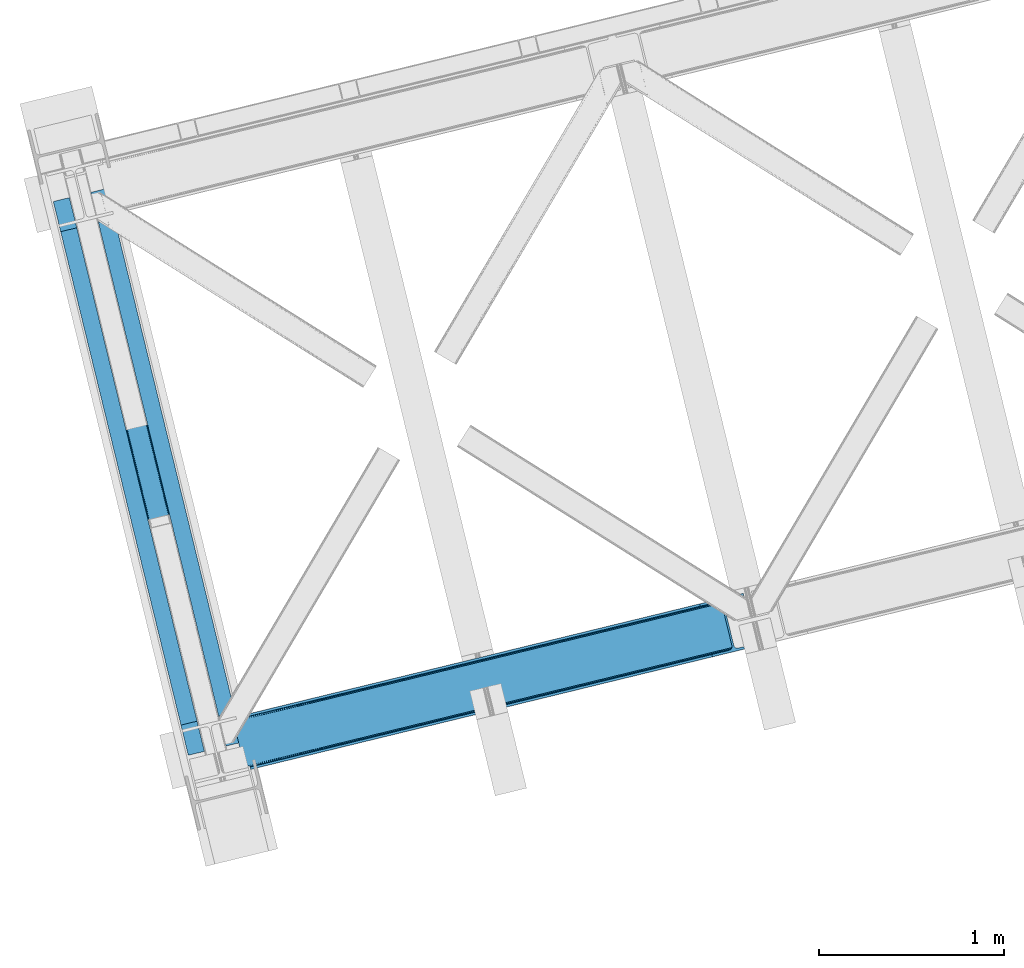
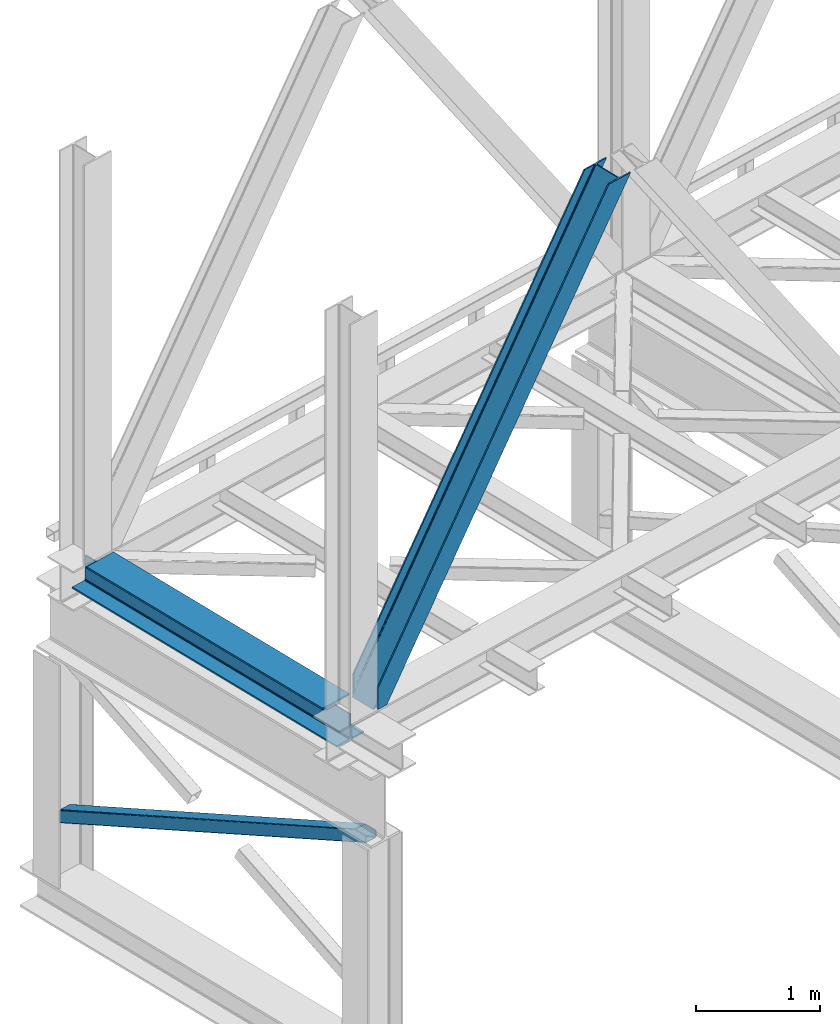
# One storey, part 23 of 93: 2 members, 1 beam.
"""IFC4 building model written with IfcOpenShell, lengths in millimetres."""

from ifc_helpers import new_model, entity, si_unit, converted_unit, derived_unit, direction, frame, origin, place, context, subcontext, project, spatial, triangles, polygons, material, type_object, element, save


model = new_model("IFC4")

# Units and contexts
model_context = context("Model", 3, precision=0.01, world=origin(), true_north=direction((6.12303176911189e-17, 1.0)))
plan_context = context("Plan", 3, precision=0.01, world=origin(), true_north=direction((6.12303176911189e-17, 1.0)))
body_context = subcontext(model_context, "Body", "Model", "MODEL_VIEW")
ifc_project = project(units=[si_unit("LENGTHUNIT", "METRE", prefix="MILLI"), si_unit("AREAUNIT", "SQUARE_METRE"), si_unit("VOLUMEUNIT", "CUBIC_METRE"), converted_unit("PLANEANGLEUNIT", "DEGREE", entity("IfcRatioMeasure", 0.0174532925199433), si_unit("PLANEANGLEUNIT", "RADIAN"), dimensions=[0, 0, 0, 0, 0, 0, 0]), si_unit("MASSUNIT", "GRAM", prefix="KILO"), derived_unit("MASSDENSITYUNIT", [(si_unit("MASSUNIT", "GRAM", prefix="KILO"), 1), (si_unit("LENGTHUNIT", "METRE"), -3)]), derived_unit("MOMENTOFINERTIAUNIT", [(si_unit("LENGTHUNIT", "METRE"), 4)]), si_unit("TIMEUNIT", "SECOND"), si_unit("FREQUENCYUNIT", "HERTZ"), si_unit("THERMODYNAMICTEMPERATUREUNIT", "DEGREE_CELSIUS"), derived_unit("THERMALTRANSMITTANCEUNIT", [(si_unit("MASSUNIT", "GRAM", prefix="KILO"), 1), (si_unit("THERMODYNAMICTEMPERATUREUNIT", "KELVIN"), -1), (si_unit("TIMEUNIT", "SECOND"), -3)]), derived_unit("VOLUMETRICFLOWRATEUNIT", [(si_unit("LENGTHUNIT", "METRE"), 3), (si_unit("TIMEUNIT", "SECOND"), -1)]), derived_unit("MASSFLOWRATEUNIT", [(si_unit("MASSUNIT", "GRAM", prefix="KILO"), 1), (si_unit("TIMEUNIT", "SECOND"), -1)]), derived_unit("ROTATIONALFREQUENCYUNIT", [(si_unit("TIMEUNIT", "SECOND"), -1)]), si_unit("ELECTRICCURRENTUNIT", "AMPERE"), si_unit("ELECTRICVOLTAGEUNIT", "VOLT"), si_unit("POWERUNIT", "WATT"), si_unit("FORCEUNIT", "NEWTON", prefix="KILO"), si_unit("ILLUMINANCEUNIT", "LUX"), si_unit("LUMINOUSFLUXUNIT", "LUMEN"), si_unit("LUMINOUSINTENSITYUNIT", "CANDELA"), derived_unit("USERDEFINED", [(si_unit("MASSUNIT", "GRAM", prefix="KILO"), -1), (si_unit("LENGTHUNIT", "METRE"), -2), (si_unit("TIMEUNIT", "SECOND"), 3), (si_unit("LUMINOUSFLUXUNIT", "LUMEN"), 1)]), derived_unit("LINEARVELOCITYUNIT", [(si_unit("LENGTHUNIT", "METRE"), 1), (si_unit("TIMEUNIT", "SECOND"), -1)]), si_unit("PRESSUREUNIT", "PASCAL"), derived_unit("USERDEFINED", [(si_unit("LENGTHUNIT", "METRE"), -2), (si_unit("MASSUNIT", "GRAM", prefix="KILO"), 1), (si_unit("TIMEUNIT", "SECOND"), -2)]), derived_unit("LINEARFORCEUNIT", [(si_unit("MASSUNIT", "GRAM", prefix="KILO"), 1), (si_unit("LENGTHUNIT", "METRE"), 1), (si_unit("TIMEUNIT", "SECOND"), -2), (si_unit("LENGTHUNIT", "METRE"), -1)]), derived_unit("PLANARFORCEUNIT", [(si_unit("MASSUNIT", "GRAM", prefix="KILO"), 1), (si_unit("LENGTHUNIT", "METRE"), 1), (si_unit("TIMEUNIT", "SECOND"), -2), (si_unit("LENGTHUNIT", "METRE"), -2)])], contexts=[model_context, plan_context])

# Site, building, storey
site_placement = place(None, origin())
site = spatial("IfcSite", under=ifc_project, at=site_placement, CompositionType="ELEMENT")
building_placement = place(site_placement, origin())
building = spatial("IfcBuilding", under=site, at=building_placement, CompositionType="ELEMENT")
storey_placement = place(building_placement, frame((0.0, 0.0, 15900.0)))
storey = spatial("IfcBuildingStorey", under=building, at=storey_placement, CompositionType="ELEMENT", Elevation=15900.0)

# Beam
ifc_material = material(Name="Metal painted (White)")
beam_type = type_object("IfcBeamType", PredefinedType="BEAM")
beam_placement = place(storey_placement, frame((-61153.9389306417, 2879.78519364395, 3385.0)))
element("IfcBeam", 1, at=beam_placement, inside=storey, type_object=beam_type, material=ifc_material, ObjectType="Steel Beam", PredefinedType="BEAM", context=body_context, shape_type="Tessellation", body=[
    polygons([(1022.42935345713, 71.0478278971005, 15.4999999999986), (1022.42935345711, 71.0478278971005, 0.0), (291.465617442429, 3069.74325535076, 0.0), (291.465617442446, 3069.74325535076, 15.4999999999986), (899.042242073153, 40.970914087328, 15.4999999999986), (168.078506058474, 3039.66634154099, 15.4999999999986), (892.34989829919, 39.3395844888232, 16.8701684147963), (161.386162284511, 3038.03501194248, 16.8701684147963), (886.676403198575, 37.9566100336508, 20.7720779386413), (155.712667183895, 3036.65203748731, 20.7720779386413), (882.88549497, 37.0325360459173, 26.6116982174294), (151.92175895532, 3035.72796349958, 26.6116982174294), (881.554305026603, 36.7080444135018, 33.500000000001), (150.590569011932, 3035.40347186716, 33.500000000001), (140.875048430514, 3033.03521093726, 33.500000000001), (140.875048430514, 3033.03521093726, 259.000000000002), (150.590569011924, 3035.40347186716, 259.000000000002), (-8.66293703438714e-12, 2998.69542745366, 0.0), (-8.66293703438714e-12, 2998.69542745366, 15.4999999999986), (123.387111383964, 3028.77234126343, 15.4999999999986), (130.079455157918, 3030.40367086194, 16.8701684147963), (135.752950258542, 3031.78664531711, 20.7720779386413), (139.543858487117, 3032.71071930484, 26.6116982174294), (881.554305026594, 36.7080444135013, 259.000000000002), (871.838784445184, 34.3397834835981, 259.000000000002), (871.838784445184, 34.3397834835981, 33.500000000001), (870.507594501779, 34.0152918511832, 26.6116982174294), (866.716686273221, 33.0912178634486, 20.7720779386413), (861.043191172597, 31.7082434082767, 16.8701684147963), (854.350847398634, 30.0769138097725, 15.4999999999986), (730.963736014671, -5.41433564649196e-13, 15.4999999999986), (730.963736014671, -5.41433564649196e-13, 0.0), (841.854534586231, 199.571930111228, 259.069791776412), (190.199733064555, 2872.911390143, 259.000000000002), (190.423126166404, 2871.99494573803, 259.61730333112), (190.43551501003, 2871.94412150426, 266.500003008253), (841.709355772731, 200.167408132522, 266.500002998871), (841.709705893475, 200.165971827788, 260.000004007589), (832.229597305436, 196.831858094284, 259.006343172366), (832.006227290712, 197.74830961273, 259.61730333112), (831.993838447078, 197.799133846503, 266.500003008253), (180.719997684385, 2869.57584721824, 266.500002998871), (180.719647563625, 2869.57728352297, 260.000004007589), (180.574841905289, 2870.17133233676, 259.07612046749), (180.484212483136, 2870.5431292131, 259.000000000002), (843.040843642659, 200.490677577208, 273.388305639783), (846.831120231346, 201.417342749121, 279.227924098781), (852.504191178885, 202.802057212798, 283.129832400619), (859.196382860018, 204.434010743611, 284.500000377228), (982.583411547862, 234.511263798722, 284.500000138971), (982.58174174121, 234.518113867454, 299.999995328161), (691.11631964394, 163.469484603412, 299.999995890962), (691.1179894506, 163.46263453468, 284.500000701776), (814.505018138427, 193.539887589791, 284.500000463519), (821.197505034574, 195.17063005637, 283.129832461069), (826.871416683335, 196.551895700895, 279.227924137322), (830.662951470335, 197.473399350192, 273.388305663684), (179.38850981445, 2869.25257777355, 273.388305639783), (175.598233225754, 2868.32591260164, 279.227924098781), (169.925162278215, 2866.94119813796, 283.129832400619), (163.232970597099, 2865.30924460715, 284.500000377228), (39.8459419092461, 2835.23199155204, 284.500000138971), (39.8476117159065, 2835.2251414833, 299.999995328161), (331.313033813168, 2906.27377074735, 299.999995890962), (331.311364006516, 2906.28062081608, 284.500000701776), (207.924335318672, 2876.20336776097, 284.500000463519), (201.231848422525, 2874.57262529439, 283.129832461069), (195.557936773773, 2873.19135964986, 279.227924137322), (191.766401986782, 2872.26985600057, 273.388305663684)], [[[1, 2, 3, 4]], [[5, 1, 4, 6]], [[7, 5, 6, 8]], [[9, 7, 8, 10]], [[11, 9, 10, 12]], [[13, 11, 12, 14]], [[15, 16, 17, 14, 12, 10, 8, 6, 4, 3, 18, 19, 20, 21, 22, 23]], [[13, 24, 25, 26, 27, 28, 29, 30, 31, 32, 2, 1, 5, 7, 9, 11]], [[2, 32, 18, 3]], [[32, 31, 19, 18]], [[31, 30, 20, 19]], [[27, 26, 15, 23]], [[28, 27, 23, 22]], [[29, 28, 22, 21]], [[30, 29, 21, 20]], [[33, 24, 13, 14, 17, 34, 35, 36, 37, 38]], [[25, 39, 40, 41, 42, 43, 44, 16, 15, 26]], [[39, 25, 24, 33]], [[45, 34, 17, 16]], [[41, 40, 38, 37, 46, 47, 48, 49, 50, 51, 52, 53, 54, 55, 56, 57]], [[42, 58, 59, 60, 61, 62, 63, 64, 65, 66, 67, 68, 69, 36, 35, 43]], [[46, 37, 36, 69]], [[47, 46, 69, 68]], [[48, 47, 68, 67]], [[49, 48, 67, 66]], [[50, 49, 66, 65]], [[51, 50, 65, 64]], [[52, 51, 64, 63]], [[53, 52, 63, 62]], [[54, 53, 62, 61]], [[55, 54, 61, 60]], [[56, 55, 60, 59]], [[57, 56, 59, 58]], [[41, 57, 58, 42]]], closed=False),
])

# Members
member_type_1 = type_object("IfcMemberType", PredefinedType="BRACE")
member_1_placement = place(storey_placement, frame((-60179.5639160156, 2803.33935241699, 3684.99990234375)))
element("IfcMember", 2, at=member_1_placement, inside=storey, type_object=member_type_1, ObjectType="Steel Vertical Brace", PredefinedType="BRACE", context=body_context, shape_type="Tessellation", body=[
    triangles([(58.5731689453096, 23.1982933044433, 0.0), (60.4660766601592, 15.4260932922361, 0.0), (59.1080200195283, 16.2394157409667, 0.781347656247817), (58.9684936523408, 15.0609992980958, 1.0697021484375), (78.1673217773423, 19.740655517578, 8.06229858398365), (78.1673217773423, 19.740655517578, 29.5563354492188), (72.7350952148408, 18.4163177490232, 0.0), (500.42061767578, 117.802693176269, 660.427130126951), (82.4554321289033, 19.9240745544435, 36.4024291992173), (86.4877441406279, 18.4526527404782, 44.3670593261704), (502.150744628903, 124.235730743408, 658.201684570311), (88.0643920898438, 17.2873168945312, 48.5435485839844), (2700.97932128907, 660.223363494873, 3921.00020141601), (2700.97001953125, 667.310721588135, 3921.00020141601), (2273.78214111328, 563.179286956787, 3287.10633544922), (2274.3169921875, 556.220118713379, 3287.88535766601), (2697.74696044922, 653.425231933594, 3921.00020141601), (2272.58686523438, 549.787371826172, 3290.11080322265), (2691.77058105469, 647.951147460938, 3921.00020141601), (2268.84755859375, 544.860056304932, 3293.43850708008), (2683.94780273438, 644.634780120849, 3921.00020141601), (2263.67578125, 542.188417053223, 3297.36384887695), (491.5048828125, 110.204029083252, 667.68017578125), (496.681311035158, 112.875377655029, 663.754833984374), (91.1758300781221, 12.6192878723145, 73.6396911621086), (90.6456298828125, 13.9003143310547, 61.2474243164033), (89.48291015625, 15.426383972168, 55.5245178222649), (501.611242675783, 131.194608306885, 657.42033691406), (945.193469238278, 232.231755065918, 1315.62202148437), (944.653967285158, 239.190632629394, 1314.84299926758), (1388.23619384765, 340.227779388428, 1973.04468383789), (1387.69669189453, 347.186947631836, 1972.26333618164), (1831.27426757813, 448.224094390869, 2630.46502075195), (1830.73941650391, 455.182971954346, 2629.6836730957), (943.458691406253, 225.799008178711, 1317.84746704101), (1386.50141601563, 333.795032501221, 1975.26780395508), (1829.544140625, 441.791347503662, 2632.68814086914), (939.724035644533, 220.871692657471, 1321.17517089844), (1382.76676025391, 328.86771697998, 1978.5955078125), (1825.80483398437, 436.864031982422, 2636.01817016601), (934.547607421875, 218.200053405762, 1325.10051269531), (1377.59033203125, 326.196077728272, 1982.52317504883), (1820.63305664063, 434.192392730713, 2639.94351196289), (91.1758300781221, 12.6192878723145, 210.054620361327), (2592.01853027344, 622.225392150879, 3921.00020141601), (1332.51866455078, 573.558595275879, 1972.26333618164), (2645.7873413086, 893.682369232178, 3921.00020141601), (2218.59946289063, 789.55093460083, 3287.10633544922), (1775.55673828125, 681.554619598388, 2629.6836730957), (889.475939941403, 465.562280273437, 1314.84299926758), (446.433215332028, 357.566255950928, 657.42033691406), (3.39049072265334, 249.569940948486, 0.0), (86.4877441406279, 18.4526527404782, 15.6757873535134), (82.4554321289033, 19.9240745544435, 13.352673339843), (84.3529907226548, 19.4549171447752, 14.892114257811), (88.0643920898438, 17.2873168945312, 15.1293090820291), (91.4595336914063, 11.6585906982423, 0.0), (90.6456298828125, 13.9003143310547, 7.3414123535149), (89.6456909179688, 15.5502136230466, 12.4201721191384), (91.4595336914063, 11.6585906982423, 210.119732666015), (91.1153686523467, 12.7907890319825, 0.0), (2595.09741210938, 609.595349121093, 3921.00020141601), (94.3012207031279, 0.0, 210.119732666015), (94.3012207031279, 0.0, 0.0), (189.179150390628, 23.1273674011231, 0.0), (2831.57600097657, 667.239795684814, 3921.00020141601), (94.1663452148423, 13.3483131408689, 0.0), (186.100268554685, 35.7577011108397, 0.0), (2828.49711914063, 679.8698387146, 3921.00020141601), (1411.90916748047, 334.561846160889, 1955.37134399414), (2305.60810546875, 552.410758209228, 3281.5159790039), (1858.76096191406, 443.486302185058, 2618.4424987793), (2736.56319580078, 657.460741424561, 3921.00020141601), (965.057373046875, 225.637390136719, 1292.29786376953), (518.210229492186, 116.712934112549, 629.226708984374), (512.387329101563, 116.703632354736, 633.152050781249), (72.1351318359375, 19.4709045410154, 0.0), (502.299572753909, 124.272356414795, 638.705200195313), (506.796972656251, 119.358121490478, 636.479754638669), (499.574157714844, 130.698126983642, 639.484222412109), (2728.0939453125, 656.806420898437, 3921.00020141601), (2299.78520507813, 552.401747131348, 3285.44132080078), (2720.26651611328, 658.914141082764, 3921.00020141601), (2294.19949951172, 555.05623626709, 3288.7690246582), (2714.27153320313, 663.462991333008, 3921.00020141601), (2289.70209960938, 559.970471191406, 3290.99447021484), (2711.02056884766, 669.760572052002, 3921.00020141601), (2286.97668457031, 566.395951080322, 3291.77349243164), (68.6237182617188, 25.6484344482419, 0.0), (959.234472656251, 225.628088378906, 1296.22320556641), (1406.08626708984, 334.552544403076, 1959.29668579101), (1852.93806152344, 443.477000427246, 2622.37016601562), (953.648767089842, 228.282577514648, 1299.55323486328), (1400.50056152344, 337.207033538818, 1962.62438964844), (1847.35235595703, 446.131489562988, 2625.69786987305), (949.1513671875, 233.196812438965, 1301.77635498047), (1396.00316162109, 342.121268463135, 1964.84983520508), (1842.85030517578, 451.046015167236, 2627.92098999023), (946.425952148435, 239.622583007812, 1302.55770263672), (1393.27774658203, 348.547039031982, 1965.62885742187), (1840.12954101562, 457.471495056152, 2628.70233764648), (1784.94686279297, 683.843142700195, 2628.70233764648), (1338.09506835938, 574.918686676025, 1965.62885742187), (2655.837890625, 896.132219696045, 3921.00020141601), (2231.79865722657, 792.767598724365, 3291.77349243164), (891.247924804688, 465.994230651856, 1302.55770263672), (444.396130371097, 357.069774627686, 639.484222412109), (13.4410400390625, 252.020082092285, 0.0), (1.49758300781104, 257.342431640625, 0.0), (13.7154418945283, 259.120811462402, 0.0), (13.7619506835908, 260.332946777344, 0.0), (0.665075683595205, 255.995711517334, 0.781347656247817), (0.0, 256.977628326416, 1.0697021484375), (19.1988281250015, 261.656993865967, 8.06229858398365), (19.1988281250015, 261.656993865967, 29.5563354492188), (439.210400390628, 368.906261444092, 660.427130126951), (433.624694824219, 371.560750579834, 663.754833984374), (27.5890136718735, 272.585396575927, 61.2474243164033), (27.4634399414063, 270.661095428467, 54.4989990234353), (443.70780029297, 363.992026519775, 658.201684570311), (23.0869628906221, 263.467639160156, 36.4024291992173), (26.5565185546875, 268.18304901123, 48.2714721679658), (25.9891113281265, 266.629364776611, 44.3670593261704), (427.801794433595, 371.551448822021, 667.68017578125), (27.4727416992173, 273.966998291015, 73.6396911621086), (2628.70931396484, 906.63622970581, 3921.00020141601), (2620.24006347657, 905.982199859619, 3921.00020141601), (2205.79094238282, 803.545138549805, 3293.43850708008), (2199.96804199219, 803.536127471924, 3297.36384887695), (2636.54139404297, 904.528509521484, 3921.00020141601), (2211.37664794922, 800.890649414062, 3290.11080322265), (2642.53637695313, 899.97965927124, 3921.00020141601), (2215.87404785156, 795.976414489746, 3287.88535766601), (876.667419433594, 479.556774902343, 1321.17517089844), (870.84451904297, 479.547473144531, 1325.10051269531), (1319.70549316406, 587.552799224854, 1978.5955078125), (1313.88259277344, 587.543788146972, 1982.52317504883), (1762.74821777344, 695.549114227295, 2636.01817016601), (1756.92531738281, 695.539812469483, 2639.94351196289), (882.253125000003, 476.902285766601, 1317.84746704101), (1325.29584960938, 584.898310089111, 1975.26780395508), (1768.33392333984, 692.894625091553, 2632.68814086914), (886.750524902345, 471.988050842285, 1315.62202148437), (1329.79324951172, 579.984365844727, 1973.04468383789), (1772.83132324219, 687.980390167236, 2630.46502075195), (2528.31079101563, 883.57310256958, 3921.00020141601), (27.4727416992173, 273.966998291015, 210.054620361327), (449.326062011722, 375.388714599609, 633.152050781249), (445.591406250001, 370.461399078369, 636.479754638669), (26.8541748046846, 268.390594482422, 15.1293090820291), (27.4634399414063, 270.661095428467, 12.4201721191384), (454.502490234372, 378.060353851318, 629.226708984374), (27.5890136718735, 272.585396575927, 7.3414123535149), (30.4632568359375, 274.695732879638, 0.0), (443.856628417969, 364.028652191162, 638.705200195313), (25.9891113281265, 266.629364776611, 15.6757873535134), (23.0869628906221, 263.467639160156, 13.352673339843), (24.5612915039092, 264.760583496094, 14.8944396972656), (2655.82858886719, 903.219577789307, 3921.00020141601), (2231.25915527344, 799.726766967774, 3290.99447021484), (2659.05629882812, 910.017418670654, 3921.00020141601), (2232.99393310547, 806.159513854981, 3288.7690246582), (2665.03732910156, 915.491503143311, 3921.00020141601), (2236.72858886719, 811.086829376221, 3285.44132080078), (2672.86010742188, 918.80816116333, 3921.00020141601), (2241.90501708985, 813.75846862793, 3281.5159790039), (27.4959960937485, 273.78706741333, 0.0), (890.70842285156, 472.953108215332, 1301.77635498047), (1337.56021728516, 581.877564239502, 1964.84983520508), (1784.40736083985, 690.802310943604, 2627.92098999023), (892.43854980469, 479.385855102539, 1299.55323486328), (1339.29034423828, 588.310601806641, 1962.62438964844), (1786.14213867188, 697.235057830811, 2625.69786987305), (896.177856445313, 484.313170623779, 1296.22320556641), (1343.0296508789, 593.237626647949, 1959.29668579101), (1789.8814453125, 702.162082672119, 2622.37016601562), (901.35428466797, 486.984809875488, 1292.29786376953), (1348.20142822266, 595.909265899658, 1955.37134399414), (1795.05322265625, 704.83401260376, 2618.4424987793), (27.2774047851563, 274.949205780029, 0.0), (27.2774047851563, 274.949205780029, 210.119732666015), (2525.23190917969, 896.203145599365, 3921.00020141601), (24.4357177734346, 286.607796478271, 210.119732666015), (24.4357177734346, 286.607796478271, 0.0), (2761.71049804688, 953.847592163086, 3921.00020141601), (2764.78937988282, 941.217258453369, 3921.00020141601), (119.313647460935, 309.735454559326, 0.0), (122.392529296878, 297.105120849609, 0.0)], [[1, 2, 3], [4, 3, 2], [5, 4, 2], [4, 5, 6], [2, 7, 5], [8, 9, 10], [11, 3, 6], [6, 8, 11], [6, 9, 8], [3, 4, 6], [10, 12, 8], [13, 14, 15], [15, 16, 13], [17, 13, 16], [16, 18, 17], [19, 17, 18], [18, 20, 19], [21, 19, 20], [20, 22, 21], [23, 24, 25], [26, 25, 24], [26, 8, 27], [26, 24, 8], [12, 27, 8], [11, 28, 3], [1, 3, 28], [29, 30, 28], [28, 11, 29], [31, 32, 30], [30, 29, 31], [33, 34, 32], [32, 31, 33], [16, 15, 34], [34, 33, 16], [35, 29, 11], [11, 8, 35], [36, 31, 29], [29, 35, 36], [37, 33, 31], [31, 36, 37], [18, 16, 33], [33, 37, 18], [38, 35, 24], [8, 24, 35], [39, 36, 38], [35, 38, 36], [40, 37, 39], [36, 39, 37], [20, 18, 40], [37, 40, 18], [41, 38, 24], [24, 23, 41], [42, 39, 38], [38, 41, 42], [43, 40, 39], [39, 42, 43], [22, 20, 40], [40, 43, 22], [42, 44, 45], [45, 22, 43], [22, 45, 21], [43, 42, 45], [44, 42, 41], [41, 23, 44], [25, 44, 23], [34, 46, 32], [14, 47, 48], [49, 15, 48], [46, 34, 49], [48, 15, 14], [49, 34, 15], [32, 50, 30], [50, 51, 28], [50, 32, 46], [52, 1, 51], [50, 28, 30], [51, 1, 28], [53, 10, 9], [9, 54, 55], [56, 27, 12], [56, 12, 10], [10, 53, 56], [57, 26, 58], [58, 26, 27], [27, 59, 58], [57, 60, 25], [44, 25, 60], [25, 26, 57], [58, 61, 57], [56, 59, 27], [9, 55, 53], [54, 9, 6], [6, 5, 54], [62, 60, 63], [62, 45, 60], [44, 60, 45], [64, 63, 60], [60, 57, 64], [62, 65, 66], [65, 62, 63], [64, 65, 63], [65, 67, 64], [67, 65, 68], [61, 57, 67], [57, 64, 67], [69, 66, 68], [65, 68, 66], [70, 69, 68], [71, 69, 72], [71, 73, 69], [70, 72, 69], [68, 74, 70], [75, 74, 68], [68, 67, 75], [76, 59, 56], [76, 58, 59], [77, 78, 5], [78, 55, 54], [78, 53, 55], [54, 5, 78], [5, 7, 77], [78, 79, 56], [56, 53, 78], [80, 78, 77], [67, 61, 58], [76, 75, 58], [67, 58, 75], [81, 73, 71], [71, 82, 81], [83, 81, 82], [82, 84, 83], [85, 83, 84], [84, 86, 85], [87, 85, 86], [86, 88, 87], [77, 89, 80], [56, 79, 76], [90, 74, 75], [75, 76, 90], [91, 70, 90], [74, 90, 70], [92, 72, 91], [70, 91, 72], [82, 71, 92], [72, 92, 71], [93, 90, 76], [76, 79, 93], [94, 91, 90], [90, 93, 94], [95, 92, 91], [91, 94, 95], [84, 82, 92], [92, 95, 84], [96, 93, 78], [79, 78, 93], [97, 94, 93], [93, 96, 97], [98, 95, 94], [94, 97, 98], [86, 84, 95], [95, 98, 86], [99, 96, 80], [78, 80, 96], [100, 97, 99], [96, 99, 97], [101, 98, 100], [97, 100, 98], [88, 86, 101], [98, 101, 86], [102, 100, 103], [104, 87, 88], [101, 105, 88], [100, 102, 101], [88, 105, 104], [101, 102, 105], [103, 99, 106], [99, 80, 107], [99, 103, 100], [89, 108, 80], [99, 107, 106], [80, 108, 107], [109, 108, 110], [1, 89, 108], [1, 108, 52], [1, 2, 89], [109, 52, 108], [7, 77, 2], [77, 89, 2], [110, 111, 109], [109, 52, 112], [112, 113, 109], [113, 114, 109], [113, 115, 114], [111, 109, 114], [116, 117, 118], [118, 119, 116], [120, 121, 115], [115, 112, 120], [115, 113, 112], [120, 116, 122], [122, 123, 120], [123, 121, 120], [119, 122, 116], [117, 124, 125], [125, 118, 117], [126, 127, 128], [129, 128, 127], [130, 126, 131], [128, 131, 126], [132, 130, 133], [131, 133, 130], [47, 132, 48], [133, 48, 132], [134, 135, 124], [124, 117, 134], [136, 137, 134], [135, 134, 137], [138, 139, 136], [137, 136, 139], [128, 129, 138], [139, 138, 129], [140, 134, 117], [117, 116, 140], [141, 136, 134], [134, 140, 141], [142, 138, 136], [136, 141, 142], [131, 128, 138], [138, 142, 131], [143, 140, 120], [116, 120, 140], [144, 141, 143], [140, 143, 141], [145, 142, 144], [141, 144, 142], [133, 131, 145], [142, 145, 131], [51, 120, 112], [112, 52, 51], [50, 143, 51], [120, 51, 143], [46, 144, 50], [143, 50, 144], [49, 145, 46], [144, 46, 145], [48, 133, 49], [145, 49, 133], [146, 147, 137], [137, 139, 146], [139, 129, 146], [127, 146, 129], [135, 137, 147], [147, 125, 124], [124, 135, 147], [148, 149, 150], [150, 151, 148], [152, 148, 153], [153, 154, 152], [107, 108, 110], [155, 156, 150], [155, 110, 114], [114, 157, 155], [157, 158, 155], [158, 156, 155], [110, 111, 114], [150, 149, 155], [110, 155, 107], [159, 104, 160], [105, 160, 104], [161, 159, 162], [160, 162, 159], [163, 161, 164], [162, 164, 161], [165, 163, 166], [164, 166, 163], [153, 167, 154], [151, 153, 148], [168, 106, 107], [107, 155, 168], [169, 103, 106], [106, 168, 169], [170, 102, 103], [103, 169, 170], [160, 105, 102], [102, 170, 160], [171, 168, 155], [155, 149, 171], [172, 169, 171], [168, 171, 169], [173, 170, 172], [169, 172, 170], [162, 160, 173], [170, 173, 160], [174, 171, 148], [149, 148, 171], [175, 172, 174], [171, 174, 172], [176, 173, 175], [172, 175, 173], [164, 162, 176], [173, 176, 162], [177, 174, 152], [148, 152, 174], [178, 175, 174], [174, 177, 178], [179, 176, 175], [175, 178, 179], [166, 164, 176], [176, 179, 166], [156, 158, 121], [121, 123, 156], [150, 156, 123], [123, 122, 150], [119, 151, 150], [118, 153, 119], [151, 119, 153], [180, 167, 153], [153, 125, 180], [181, 180, 125], [125, 147, 181], [118, 125, 153], [122, 119, 150], [158, 157, 121], [121, 157, 115], [114, 115, 157], [182, 181, 146], [181, 182, 183], [181, 147, 146], [180, 181, 184], [183, 184, 181], [47, 14, 104], [17, 19, 81], [21, 62, 66], [45, 62, 21], [19, 21, 73], [14, 13, 85], [13, 17, 83], [130, 163, 126], [182, 127, 185], [127, 126, 165], [182, 146, 127], [130, 132, 161], [132, 47, 159], [104, 14, 87], [73, 81, 19], [85, 13, 83], [81, 83, 17], [85, 87, 14], [66, 73, 21], [66, 69, 73], [165, 126, 163], [161, 132, 159], [104, 159, 47], [161, 163, 130], [165, 185, 127], [185, 165, 186], [187, 154, 184], [154, 187, 188], [167, 180, 154], [180, 184, 154], [182, 187, 183], [182, 185, 187], [187, 184, 183], [186, 178, 188], [179, 186, 166], [186, 179, 178], [186, 165, 166], [177, 188, 178], [154, 188, 152], [177, 152, 188], [185, 186, 188], [188, 187, 185]]),
])
member_type_2 = type_object("IfcMemberType", PredefinedType="BRACE")
member_2_placement = place(storey_placement, frame((-61123.5760620117, 2666.95552597046, 911.279672241211)))
element("IfcMember", 3, at=member_2_placement, inside=storey, type_object=member_type_2, ObjectType="Steel Vertical Brace", PredefinedType="BRACE", context=body_context, shape_type="Tessellation", body=[
    triangles([(109.78864746094, 3493.74459457398, 0.0), (954.899853515628, 26.7614479064941, 1610.78191223144), (6.80423583984521, 3468.64147567749, 0.0), (851.915441894533, 1.65774765014658, 1610.78191223144), (112.19315185547, 3494.33118667603, 1.12551269531104), (957.304357910158, 27.3474586486818, 1611.90626220703), (114.59765625, 3494.91719741821, 2.24986267089844), (959.708862304688, 27.9334693908695, 1613.03061218261), (115.592944335935, 3495.1596244812, 4.96481323242188), (960.704150390622, 28.1761871337894, 1615.74672546387), (116.588232421876, 3495.40263290405, 7.68092651366896), (961.704089355466, 28.4191955566407, 1618.46167602539), (0.99993896484375, 3467.22644577026, 4.96481323242188), (846.111145019531, 0.242717742919922, 1615.74672546387), (0.0, 3466.98343734741, 7.68092651366896), (845.115856933597, 0.0, 1618.46167602539), (1.99522705077834, 3467.46887283325, 2.24986267089844), (847.106433105466, 0.485435485839844, 1613.03061218261), (4.39973144531541, 3468.05488357544, 1.12551269531104), (849.510937500003, 1.07173690795935, 1611.90626220703), (933.347680664061, 144.732444763184, 1680.7206665039), (116.588232421876, 3495.40263290405, 123.979641723632), (961.704089355466, 28.4191955566407, 1680.7206665039), (816.764099121094, 116.313249206543, 1680.7206665039), (0.0, 3466.98343734741, 123.979641723632), (845.115856933597, 0.0, 1680.7206665039), (112.19315185547, 3494.33118667603, 130.53505554199), (109.78864746094, 3493.74459457398, 131.659405517577), (922.52043457031, 159.605083465576, 1680.7206665039), (114.59765625, 3494.91719741821, 129.409542846679), (925.427233886716, 158.981284332276, 1680.7206665039), (115.592944335935, 3495.1596244812, 126.694592285156), (928.506115722659, 155.935540008545, 1680.7206665039), (931.287341308591, 150.932066345215, 1680.7206665039), (6.80423583984521, 3468.64147567749, 131.659405517577), (819.536022949222, 134.501383209229, 1680.7206665039), (815.740905761719, 122.76547164917, 1680.7206665039), (0.99993896484375, 3467.22644577026, 126.694592285156), (815.903686523438, 128.487796783447, 1680.7206665039), (1.99522705077834, 3467.46887283325, 129.409542846679), (817.23848876953, 132.608766174317, 1680.7206665039), (4.39973144531541, 3468.05488357544, 130.53505554199), (923.45061035156, 145.989635467529, 1680.7206665039), (926.529492187503, 142.944181823731, 1680.7206665039), (920.539160156251, 146.61343460083, 1680.7206665039), (931.371057128905, 131.74108657837, 1680.7206665039), (956.843920898435, 27.234965515137, 1680.7206665039), (929.310717773435, 137.9407081604, 1680.7206665039), (823.642749023435, 117.864317321777, 1680.7206665039), (824.972900390625, 121.985577392578, 1680.7206665039), (827.27043457031, 123.878194427491, 1680.7206665039), (824.498510742189, 105.690060424805, 1680.7206665039), (823.475317382814, 112.142282867432, 1680.7206665039), (849.971374511719, 1.18423004150418, 1680.7206665039), (111.728063964845, 3494.21840286255, 118.492767333984), (110.732775878903, 3493.97597579956, 121.208880615231), (109.737487792969, 3493.73296737671, 123.923831176755), (107.332983398439, 3493.14695663452, 125.048181152342), (104.928479003909, 3492.56094589233, 126.173693847653), (11.6597534179673, 3469.82512435913, 126.173693847653), (9.2552490234375, 3469.23911361694, 125.048181152342), (6.85074462890771, 3468.65310287476, 123.923831176755), (5.85545654296584, 3468.4100944519, 121.208880615231), (4.86016845703125, 3468.16766738892, 118.492767333984), (111.728063964845, 3494.21840286255, 13.166638183593), (956.843920898435, 27.234965515137, 1623.94738769531), (4.86016845703125, 3468.16766738892, 13.166638183593), (849.971374511719, 1.18423004150418, 1623.94738769531), (109.737487792969, 3493.73296737671, 7.73557434081886), (107.332983398439, 3493.14695663452, 6.61122436523146), (110.732775878903, 3493.97597579956, 10.4505249023423), (104.928479003909, 3492.56094589233, 5.48571166992042), (6.85074462890771, 3468.65310287476, 7.73557434081886), (5.85545654296584, 3468.4100944519, 10.4505249023423), (9.2552490234375, 3469.23911361694, 6.61122436523146), (11.6597534179673, 3469.82512435913, 5.48571166992042), (950.044335937499, 25.5772178649904, 1616.26762390137), (952.448840332028, 26.1632286071781, 1617.39197387695), (954.853344726565, 26.7495300292971, 1618.51748657227), (856.775610351564, 2.84197769165075, 1616.26762390137), (854.371105957034, 2.25567626953125, 1617.39197387695), (851.966601562497, 1.66966552734402, 1618.51748657227), (955.8486328125, 26.9922477722171, 1621.23243713379), (850.971313476563, 1.4269477844241, 1621.23243713379)], [[1, 2, 3], [4, 3, 2], [5, 6, 2], [2, 1, 5], [7, 8, 6], [6, 5, 7], [9, 10, 8], [8, 7, 9], [11, 12, 10], [10, 9, 11], [13, 14, 15], [16, 15, 14], [17, 18, 13], [14, 13, 18], [19, 20, 17], [18, 17, 20], [3, 4, 19], [20, 19, 4], [11, 21, 12], [21, 11, 22], [23, 12, 21], [24, 15, 16], [24, 25, 15], [16, 26, 24], [27, 28, 29], [30, 27, 31], [32, 30, 33], [22, 32, 34], [34, 21, 22], [33, 34, 32], [31, 33, 30], [29, 31, 27], [29, 28, 35], [35, 36, 29], [25, 24, 37], [38, 37, 39], [40, 39, 41], [42, 41, 36], [36, 35, 42], [41, 42, 40], [39, 40, 38], [37, 38, 25], [43, 44, 34], [33, 43, 34], [29, 33, 31], [45, 29, 36], [33, 45, 43], [29, 45, 33], [44, 21, 34], [23, 46, 47], [23, 21, 46], [44, 48, 21], [48, 46, 21], [37, 49, 50], [36, 51, 45], [51, 39, 50], [39, 51, 36], [50, 39, 37], [39, 36, 41], [24, 49, 37], [52, 53, 24], [53, 49, 24], [52, 26, 54], [24, 26, 52], [55, 46, 48], [56, 48, 44], [57, 44, 43], [58, 43, 45], [45, 59, 58], [43, 58, 57], [44, 57, 56], [48, 56, 55], [59, 45, 51], [51, 60, 59], [61, 60, 51], [62, 61, 50], [63, 62, 49], [64, 63, 53], [53, 52, 64], [49, 53, 63], [50, 49, 62], [51, 50, 61], [46, 65, 66], [46, 55, 65], [66, 47, 46], [67, 52, 68], [52, 67, 64], [54, 68, 52], [58, 59, 28], [32, 57, 27], [32, 27, 30], [28, 59, 35], [28, 27, 58], [57, 58, 27], [55, 22, 11], [22, 56, 57], [55, 56, 22], [22, 57, 32], [42, 62, 38], [60, 35, 59], [61, 42, 35], [61, 35, 60], [38, 40, 42], [62, 25, 38], [42, 61, 62], [62, 63, 25], [25, 64, 15], [64, 25, 63], [69, 5, 70], [11, 65, 55], [71, 11, 69], [11, 71, 65], [69, 11, 9], [70, 1, 72], [69, 9, 5], [5, 9, 7], [72, 1, 3], [5, 1, 70], [73, 13, 15], [74, 73, 15], [75, 19, 73], [67, 15, 64], [15, 67, 74], [19, 13, 73], [3, 76, 72], [19, 75, 3], [76, 3, 75], [17, 13, 19], [77, 4, 2], [2, 6, 78], [6, 8, 10], [6, 79, 78], [2, 78, 77], [79, 6, 10], [80, 4, 77], [18, 20, 14], [20, 4, 81], [81, 82, 20], [20, 82, 14], [80, 81, 4], [14, 82, 16], [83, 12, 66], [10, 12, 79], [83, 79, 12], [23, 66, 12], [23, 47, 66], [16, 84, 68], [84, 16, 82], [68, 26, 16], [26, 68, 54], [77, 72, 76], [76, 80, 77], [66, 65, 83], [71, 83, 65], [83, 71, 79], [69, 79, 71], [79, 69, 78], [70, 78, 69], [78, 70, 77], [72, 77, 70], [80, 76, 75], [75, 81, 80], [81, 75, 73], [73, 82, 81], [82, 73, 74], [74, 84, 82], [84, 74, 67], [67, 68, 84]]),
])

save(model, "model.ifc")
